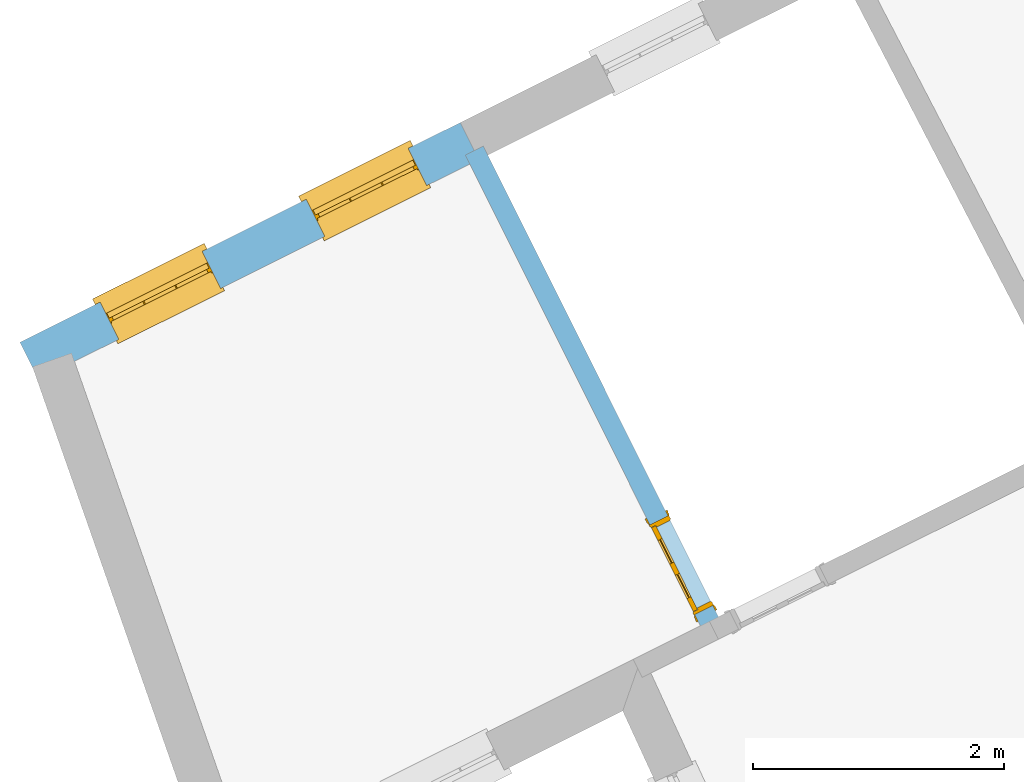
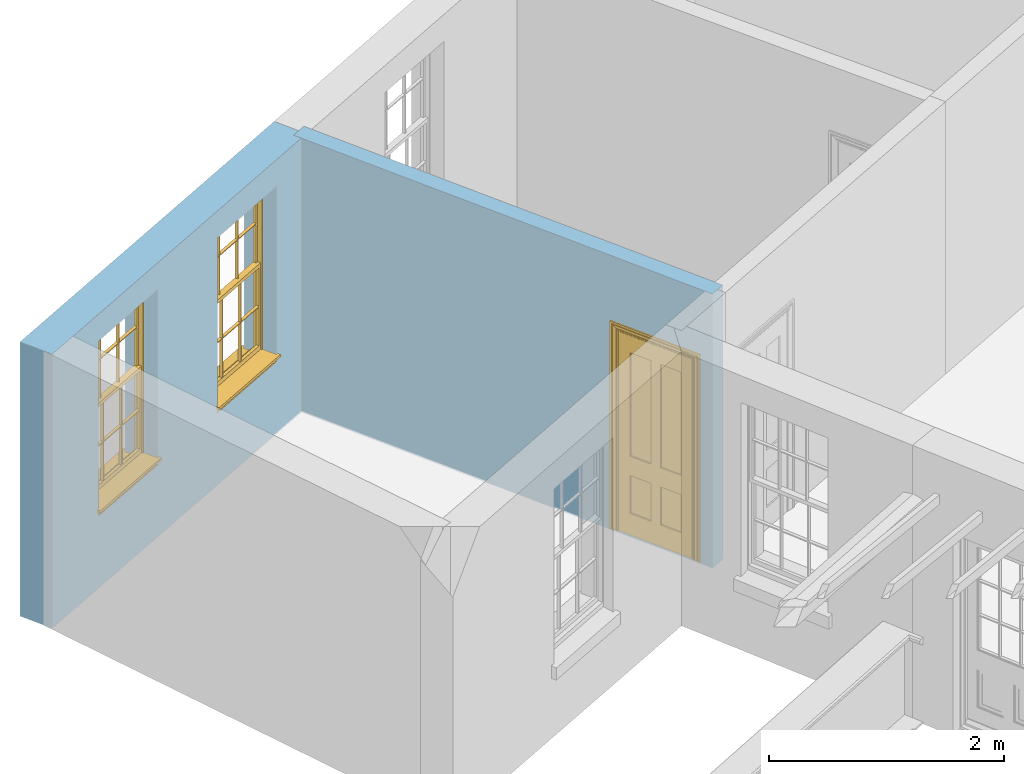
# One storey, part 5 of 9: 2 windows, 1 door, 3 openings, plus 2 elements that do not belong to this part.
"""IFC2X3 building model written with IfcOpenShell, lengths in metres."""

import ifcopenshell
import ifcopenshell.guid

model = None  # the IFC model being written
_history = None  # IfcOwnerHistory: only IFC2X3 demands one
_inside = {}  # id of a spatial element -> (the spatial element, [elements in it])
_under = {}  # id of a project, library or spatial element -> (it, [spatial elements below it])
_declared = {}  # id of a project -> (the project, [libraries it declares])
_typed = {}  # id of a type object -> (the type object, [elements of that type])
_made_of = {}  # id of a material, layer set ... -> (it, [elements and type objects made of it])


def new_model(schema):
    """Start an empty IFC model of exactly this schema.

    Asked for "IFC4X3", IfcOpenShell would pick the latest addendum, in which some entities
    have other attributes; the version numbers below select the first issue.
    IFC2X3 requires an IfcOwnerHistory on every rooted entity: one is made here for all.
    """
    global model, _history
    if schema == "IFC4X3":
        model = ifcopenshell.file(schema_version=(4, 3, 0, 0))
    else:
        model = ifcopenshell.file(schema=schema)
    _inside.clear()
    _under.clear()
    _declared.clear()
    _typed.clear()
    _made_of.clear()
    _history = None
    if model.schema == "IFC2X3":
        org = make("IfcOrganization", Name="unknown")
        user = make(
            "IfcPersonAndOrganization",
            ThePerson=make("IfcPerson", FamilyName="unknown"),
            TheOrganization=org,
        )
        app = make(
            "IfcApplication",
            ApplicationDeveloper=org,
            Version="unknown",
            ApplicationFullName="unknown",
            ApplicationIdentifier="unknown",
        )
        _history = make(
            "IfcOwnerHistory",
            OwningUser=user,
            OwningApplication=app,
            ChangeAction="ADDED",
            CreationDate=0,
        )
    return model


def make(cls, **values):
    """One entity of the class cls with the attributes given. An attribute that is None is left unset."""
    return model.create_entity(
        cls, **{name: value for name, value in values.items() if value is not None}
    )


def rooted(cls, **values):
    """An entity with a GlobalId (a new one), such as an element, a storey or a relation."""
    return make(cls, GlobalId=ifcopenshell.guid.new(), OwnerHistory=_history, **values)


def si_unit(unit_type, name, prefix=None):
    """IfcSIUnit, for example si_unit("LENGTHUNIT", "METRE", prefix="MILLI")."""
    return make("IfcSIUnit", UnitType=unit_type, Prefix=prefix, Name=name)


def assignment(units):
    """IfcUnitAssignment: the units of a project."""
    return None if units is None else make("IfcUnitAssignment", Units=units)


def point(xyz):
    """IfcCartesianPoint."""
    return None if xyz is None else make("IfcCartesianPoint", Coordinates=xyz)


def direction(xyz):
    """IfcDirection."""
    return None if xyz is None else make("IfcDirection", DirectionRatios=xyz)


def frame(location, z_axis=None, x_axis=None):
    """IfcAxis2Placement3D, a coordinate frame: its origin and axes. An axis left out is left unset."""
    return make(
        "IfcAxis2Placement3D",
        Location=point(location),
        Axis=direction(z_axis),
        RefDirection=direction(x_axis),
    )


def origin():
    """The frame at (0, 0, 0) with its axes left unset."""
    return frame((0.0, 0.0, 0.0))


def place(relative_to, where):
    """IfcLocalPlacement: puts the frame where relative to a parent placement (None: the world)."""
    return make(
        "IfcLocalPlacement", PlacementRelTo=relative_to, RelativePlacement=where
    )


def context(
    kind, dimensions, precision=None, world=None, true_north=None, identifier=None
):
    """IfcGeometricRepresentationContext, for example the 3D "Model" context."""
    return make(
        "IfcGeometricRepresentationContext",
        ContextIdentifier=identifier,
        ContextType=kind,
        CoordinateSpaceDimension=dimensions,
        Precision=precision,
        WorldCoordinateSystem=world,
        TrueNorth=true_north,
    )


def subcontext(parent, identifier, kind, view, scale=None):
    """IfcGeometricRepresentationSubContext, for example "Body" below "Model"."""
    return make(
        "IfcGeometricRepresentationSubContext",
        ContextIdentifier=identifier,
        ContextType=kind,
        ParentContext=parent,
        TargetScale=scale,
        TargetView=view,
    )


def project(units=None, contexts=None):
    """IfcProject with its units and contexts."""
    return rooted(
        "IfcProject",
        Name="project",
        RepresentationContexts=contexts,
        UnitsInContext=assignment(units),
    )


def spatial(cls, under=None, at=None, **own):
    """A site, building, storey or space (cls), placed at a placement, below another one or the project."""
    s = rooted(cls, ObjectPlacement=at, **own)
    if under is not None:
        _under.setdefault(under.id(), (under, []))[1].append(s)
    return s


def polyline(points):
    """IfcPolyline through the points."""
    return make("IfcPolyline", Points=[point(p) for p in points])


def outline(outer, holes=None, kind="AREA"):
    """IfcArbitraryClosedProfileDef: a profile drawn as a closed curve; with holes, ...WithVoids."""
    if holes is None:
        return make("IfcArbitraryClosedProfileDef", ProfileType=kind, OuterCurve=outer)
    return make(
        "IfcArbitraryProfileDefWithVoids",
        ProfileType=kind,
        OuterCurve=outer,
        InnerCurves=holes,
    )


def extrude(swept, where, along, depth):
    """IfcExtrudedAreaSolid: the profile swept, set in the frame where, extruded along a direction by depth."""
    return make(
        "IfcExtrudedAreaSolid",
        SweptArea=swept,
        Position=where,
        ExtrudedDirection=direction(along),
        Depth=depth,
    )


def faces_of(points, faces, orient=None, outer=None):
    """IfcFace entities. A face is a list of loops; a loop is a list of indices into points, from 0.

    orient and outer hold one flag for each loop. By default every Orientation is true, the
    first loop of a face is its IfcFaceOuterBound and the others are IfcFaceBound.
    """
    made = []
    for i, loops in enumerate(faces):
        bounds = []
        for j, loop in enumerate(loops):
            is_outer = j == 0 if outer is None else outer[i][j]
            bounds.append(
                make(
                    "IfcFaceOuterBound" if is_outer else "IfcFaceBound",
                    Bound=make("IfcPolyLoop", Polygon=[points[k] for k in loop]),
                    Orientation=True if orient is None else orient[i][j],
                )
            )
        made.append(make("IfcFace", Bounds=bounds))
    return made


def faceted_brep(points, faces, orient=None, outer=None, voids=None):
    """IfcFacetedBrep: a solid bounded by flat faces; with voids (closed shells), ...WithVoids."""
    shared = [point(p) for p in points]
    hull = make("IfcClosedShell", CfsFaces=faces_of(shared, faces, orient, outer))
    if voids is None:
        return make("IfcFacetedBrep", Outer=hull)
    return make(
        "IfcFacetedBrepWithVoids",
        Outer=hull,
        Voids=[
            make(cls, CfsFaces=faces_of(shared, fs, o, b)) for cls, fs, o, b in voids
        ],
    )


def shape(context_of_items, identifier, shape_type, items):
    """IfcShapeRepresentation: the items that make up one representation, for example the "Body"."""
    return make(
        "IfcShapeRepresentation",
        ContextOfItems=context_of_items,
        RepresentationIdentifier=identifier,
        RepresentationType=shape_type,
        Items=items,
    )


def material(Name=None, Category=None):
    """IfcMaterial."""
    return make("IfcMaterial", Name=Name, Category=Category)


def layer(
    of_material, thickness, ventilated=None, Name=None, Category=None, Priority=None
):
    """IfcMaterialLayer: one layer of a wall or slab, of a material (None: an air gap)."""
    return make(
        "IfcMaterialLayer",
        Material=of_material,
        LayerThickness=thickness,
        IsVentilated=ventilated,
        Name=Name,
        Category=Category,
        Priority=Priority,
    )


def layer_set(layers, Name=None):
    """IfcMaterialLayerSet."""
    return make("IfcMaterialLayerSet", MaterialLayers=layers, LayerSetName=Name)


def layer_usage(for_layer_set, set_direction, sense, offset, extent=None):
    """IfcMaterialLayerSetUsage: how a layer set lies in its element."""
    return make(
        "IfcMaterialLayerSetUsage",
        ForLayerSet=for_layer_set,
        LayerSetDirection=set_direction,
        DirectionSense=sense,
        OffsetFromReferenceLine=offset,
        ReferenceExtent=extent,
    )


def made_of(thing, what):
    """Note that an element or type object is made of a material, layer set ...; save() writes the relation."""
    if what is not None:
        _made_of.setdefault(what.id(), (what, []))[1].append(thing)
    return thing


def element(
    cls,
    number,
    at=None,
    inside=None,
    cuts=None,
    type_object=None,
    material=None,
    context=None,
    identifier="Body",
    shape_type=None,
    held_by="IfcProductDefinitionShape",
    body=None,
    shapes=None,
    **own,
):
    """One element of the class cls, such as IfcWall. Its Tag is "e" and its number.

    at: its placement. inside: the storey or other place that contains it. cuts: it is an
    opening in that element (IfcRelVoidsElement). A single representation is given by context,
    identifier, shape_type and body (its items); several are given by shapes. held_by: the class
    of the entity that holds the representations. save() writes the other relations.
    """
    e = rooted(cls, Tag="e%d" % number, ObjectPlacement=at, **own)
    if body is not None:
        shapes = [shape(context, identifier, shape_type, body)]
    if shapes is not None:
        e.Representation = make(held_by, Representations=shapes)
    if inside is not None:
        _inside.setdefault(inside.id(), (inside, []))[1].append(e)
    if cuts is not None:
        rooted(
            "IfcRelVoidsElement", RelatingBuildingElement=cuts, RelatedOpeningElement=e
        )
    if type_object is not None:
        _typed.setdefault(type_object.id(), (type_object, []))[1].append(e)
    return made_of(e, material)


def fill(opening, filler):
    """IfcRelFillsElement: the door or window that sits in an opening."""
    return rooted(
        "IfcRelFillsElement",
        RelatingOpeningElement=opening,
        RelatedBuildingElement=filler,
    )


def aggregate(whole, parts):
    """IfcRelAggregates: a whole, such as a stair, and the parts it consists of."""
    return rooted("IfcRelAggregates", RelatingObject=whole, RelatedObjects=parts)


def save(model, path):
    """Write the relations noted so far, then the file.

    IfcRelAggregates (storeys below a building ...), IfcRelContainedInSpatialStructure (elements
    in a storey), IfcRelDefinesByType, IfcRelAssociatesMaterial and IfcRelDeclares: one each for
    every whole, place, type object, material and project.
    """
    for whole, parts in _under.values():
        aggregate(whole, parts)
    for where, things in _inside.values():
        rooted(
            "IfcRelContainedInSpatialStructure",
            RelatedElements=things,
            RelatingStructure=where,
        )
    for kind, things in _typed.values():
        rooted("IfcRelDefinesByType", RelatedObjects=things, RelatingType=kind)
    for what, things in _made_of.values():
        rooted("IfcRelAssociatesMaterial", RelatedObjects=things, RelatingMaterial=what)
    for by, libraries in _declared.values():
        rooted("IfcRelDeclares", RelatingContext=by, RelatedDefinitions=libraries)
    model.write(path)


model = new_model("IFC2X3")

# Units and contexts
model_context = context("Model", 3, world=origin())
body_context = subcontext(model_context, "Body", "Model", "MODEL_VIEW")
ifc_project = project(units=[si_unit("PLANEANGLEUNIT", "RADIAN"), si_unit("MASSUNIT", "GRAM", prefix="KILO"), si_unit("FORCEUNIT", "NEWTON", prefix="KILO"), si_unit("LENGTHUNIT", "METRE")], contexts=[model_context])

# Site, building, storey
site_placement = place(None, origin())
site = spatial("IfcSite", under=ifc_project, at=site_placement, CompositionType="ELEMENT")
building_placement = place(None, origin())
building = spatial("IfcBuilding", under=site, at=building_placement, Name="Building plot-8", CompositionType="ELEMENT")
storey_placement = place(None, frame((0.0, 0.0, 3.45)))
storey = spatial("IfcBuildingStorey", under=building, at=storey_placement, Name="Floor 1", CompositionType="ELEMENT", Elevation=3.45)

# Wall, openings, windows
ifc_material_1 = material(Name="Masonry")
ifc_layer_1 = layer(ifc_material_1, 0.33, ventilated=False)
ifc_layer_set_1 = layer_set([ifc_layer_1], Name="My Wall")
ifc_layer_usage_1 = layer_usage(ifc_layer_set_1, "AXIS2", "NEGATIVE", 0.08)
wall_1_placement = place(storey_placement, origin())
wall_1 = element("IfcWallStandardCase", 1, at=wall_1_placement, inside=storey, material=ifc_layer_usage_1, Name="exterior", context=body_context, shape_type="SweptSolid", body=[
    extrude(outline(polyline([(22.5334147953, 17.1075198586967), (22.3860129541837, 17.4027700868685), (18.8749875286192, 15.6499124679644), (19.0223893697354, 15.3546622397925), (22.5334147953, 17.1075198586967)])), origin(), (0.0, 0.0, 1.0), 2.85),
])
opening_1_placement = place(storey_placement, frame((0.0, 0.0, 0.75)))
opening_1 = element("IfcOpeningElement", 2, at=opening_1_placement, cuts=wall_1, Name="Opening", ObjectType="Opening", context=body_context, shape_type="SweptSolid", body=[
    extrude(outline(polyline([(21.9712626374257, 17.1957085693475), (21.1570877658003, 16.7892368256633), (21.3044896069165, 16.4939865974914), (22.118664478542, 16.9004583411757), (21.9712626374257, 17.1957085693475)])), origin(), (0.0, 0.0, 1.0), 1.82),
])
opening_2_placement = place(storey_placement, frame((0.0, 0.0, 0.75)))
opening_2 = element("IfcOpeningElement", 3, at=opening_2_placement, cuts=wall_1, Name="Opening", ObjectType="Opening", context=body_context, shape_type="SweptSolid", body=[
    extrude(outline(polyline([(20.3275871322843, 16.3751137906213), (19.5134122606589, 15.9686420469371), (19.6608141017751, 15.6733918187652), (20.4749889734006, 16.0798635624495), (20.3275871322843, 16.3751137906213)])), origin(), (0.0, 0.0, 1.0), 1.82),
])
window_1_placement = place(storey_placement, frame((22.0829306988774, 16.9720341540658, 0.75), z_axis=(0.0, 0.0, 1.0), x_axis=(-0.814174871625433, -0.406471743684243, 0.0)))
window_1 = element("IfcWindow", 4, at=window_1_placement, inside=storey, Name="bedroom outside window", OverallHeight=1.82, OverallWidth=0.91, context=body_context, shape_type="Brep", held_by="IfcProductRepresentation", body=[
    faceted_brep([(0.033125, -0.105, 0.975209), (0.01, -0.105, 0.975209), (0.033125, -0.105, 1.376042), (0.876875, -0.105, 0.975209), (0.876875, -0.105, 1.376042), (0.9, -0.105, 0.975209), (0.876875, -0.105, 1.386042), (0.876875, -0.105, 1.786875), (0.9, -0.105, 1.81), (0.033125, -0.105, 1.786875), (0.033125, -0.105, 1.386042), (0.01, -0.105, 1.81), (0.876875, -0.135, 1.376042), (0.876875, -0.135, 0.975209), (0.9, -0.135, 0.937083), (0.033125, -0.135, 1.786875), (0.01, -0.135, 1.81), (0.033125, -0.135, 1.386042), (0.01, -0.135, 0.937083), (0.033125, -0.135, 0.975209), (0.033125, -0.135, 1.376042), (0.876875, -0.135, 1.786875), (0.876875, -0.135, 1.386042), (0.9, -0.135, 1.81), (0.033125, -0.105, 0.937083), (0.01, -0.105, 0.937083), (0.033125, -0.105, 0.53625), (0.876875, -0.105, 0.937083), (0.876875, -0.105, 0.53625), (0.9, -0.105, 0.937083), (0.876875, -0.105, 0.52625), (0.876875, -0.105, 0.125417), (0.9, -0.105, 0.077167), (0.033125, -0.105, 0.125417), (0.033125, -0.105, 0.52625), (0.01, -0.105, 0.077167), (-0.0425, -0.25, 0.01), (-0.0425, -0.3, 0.001667), (0.0, -0.25, 0.01), (0.9525, -0.25, 0.01), (0.91, -0.25, 0.01), (0.9525, -0.3, 0.001667), (-0.02, 0.08, 0.077167), (0.0, 0.08, 0.077167), (-0.02, 0.11, 0.077167), (0.0, -0.06, 0.077167), (0.01, -0.06, 0.077167), (0.91, -0.06, 0.077167), (0.91, 0.08, 0.077167), (0.9, -0.06, 0.077167), (0.93, 0.08, 0.077167), (0.93, 0.11, 0.077167), (0.01, -0.075, 0.975209), (0.9, -0.075, 0.975209), (0.876875, -0.075, 0.125417), (0.876875, -0.075, 0.52625), (0.9, -0.075, 0.077167), (0.876875, -0.075, 0.53625), (0.876875, -0.075, 0.937083), (0.033125, -0.075, 0.125417), (0.01, -0.075, 0.077167), (0.033125, -0.075, 0.52625), (0.033125, -0.075, 0.937083), (0.033125, -0.075, 0.53625), (-0.02, 0.08, 0.052167), (-0.02, 0.11, 0.052167), (0.93, 0.11, 0.052167), (0.93, 0.08, 0.052167), (0.91, 0.08, 0.052167), (0.0, 0.08, 0.052167), (0.91, -0.15, 0.026667), (0.0, -0.15, 0.026667), (-0.0425, -0.3, -0.123333), (0.9525, -0.3, -0.123333), (-0.0425, -0.25, -0.123333), (0.9525, -0.25, -0.123333), (0.01, -0.06, 1.81), (0.9, -0.06, 1.81), (0.0, -0.06, 1.82), (0.91, -0.06, 1.82), (0.01, -0.15, 0.077167), (0.9, -0.15, 0.077167), (0.592292, -0.105, 0.125417), (0.592292, -0.075, 0.125417), (0.317708, -0.075, 0.125417), (0.317708, -0.105, 0.125417), (0.592292, -0.105, 0.53625), (0.317708, -0.105, 0.53625), (0.317708, -0.105, 0.52625), (0.592292, -0.105, 0.52625), (0.592292, -0.075, 0.53625), (0.317708, -0.075, 0.53625), (0.592292, -0.135, 1.386042), (0.592292, -0.105, 1.386042), (0.317708, -0.105, 1.386042), (0.317708, -0.135, 1.386042), (0.317708, -0.135, 1.376042), (0.592292, -0.135, 1.376042), (0.317708, -0.105, 1.376042), (0.592292, -0.105, 1.376042), (0.602292, -0.135, 1.376042), (0.592292, -0.135, 0.975209), (0.602292, -0.135, 0.975209), (0.602292, -0.105, 0.975209), (0.592292, -0.105, 0.975209), (0.602292, -0.105, 1.376042), (0.602292, -0.075, 0.53625), (0.602292, -0.105, 0.53625), (0.317708, -0.075, 0.52625), (0.307708, -0.075, 0.125417), (0.307708, -0.075, 0.52625), (0.602292, -0.075, 0.52625), (0.602292, -0.075, 0.125417), (0.592292, -0.075, 0.52625), (0.307708, -0.075, 0.53625), (0.317708, -0.075, 0.937083), (0.307708, -0.075, 0.937083), (0.602292, -0.075, 0.937083), (0.592292, -0.075, 0.937083), (0.307708, -0.105, 0.52625), (0.307708, -0.105, 0.125417), (0.307708, -0.105, 0.53625), (0.307708, -0.105, 0.937083), (0.592292, -0.105, 0.937083), (0.317708, -0.105, 0.937083), (0.602292, -0.105, 0.937083), (0.602292, -0.105, 0.52625), (0.602292, -0.105, 0.125417), (0.307708, -0.135, 1.386042), (0.307708, -0.135, 1.376042), (0.307708, -0.135, 0.975209), (0.317708, -0.135, 0.975209), (0.317708, -0.135, 1.786875), (0.307708, -0.135, 1.786875), (0.602292, -0.135, 1.786875), (0.592292, -0.135, 1.786875), (0.602292, -0.135, 1.386042), (0.602292, -0.105, 1.386042), (0.307708, -0.105, 1.386042), (0.307708, -0.105, 1.786875), (0.317708, -0.105, 1.786875), (0.592292, -0.105, 1.786875), (0.602292, -0.105, 1.786875), (0.307708, -0.105, 1.376042), (0.317708, -0.105, 0.975209), (0.307708, -0.105, 0.975209), (0.91, -0.15, 1.82), (0.9, -0.15, 1.81), (0.01, -0.15, 1.81), (0.0, -0.15, 1.82), (0.91, -0.25, 0.0), (0.0, -0.25, 0.0), (0.91, 0.08, 0.0), (0.0, 0.08, 0.0)], [[[0, 1, 2]], [[3, 4, 5]], [[6, 7, 8]], [[9, 10, 11]], [[12, 13, 14]], [[15, 16, 17]], [[18, 19, 20]], [[21, 22, 23]], [[24, 25, 26]], [[27, 28, 29]], [[30, 31, 32]], [[33, 34, 35]], [[14, 27, 29]], [[25, 24, 18]], [[36, 37, 38]], [[39, 40, 41]], [[42, 43, 44]], [[45, 46, 43]], [[47, 48, 49]], [[50, 51, 48]], [[1, 0, 52]], [[5, 53, 3]], [[54, 55, 56]], [[57, 58, 53]], [[59, 60, 61]], [[62, 63, 52]], [[48, 43, 46, 49]], [[51, 44, 43, 48]], [[64, 42, 44, 65]], [[65, 44, 51, 66]], [[66, 51, 50, 67]], [[65, 66, 68, 69]], [[60, 56, 49, 46]], [[70, 71, 38, 40]], [[37, 41, 40, 38]], [[37, 72, 73, 41]], [[74, 75, 73, 72]], [[8, 11, 76, 77]], [[76, 78, 79, 77]], [[32, 35, 80, 81]], [[81, 80, 71, 70]], [[82, 83, 84, 85]], [[86, 87, 88, 89]], [[86, 90, 91, 87]], [[92, 93, 94, 95]], [[92, 95, 96, 97]], [[96, 98, 99, 97]], [[100, 97, 101, 102]], [[103, 104, 99, 105]], [[97, 99, 104, 101]], [[102, 103, 105, 100]], [[28, 57, 106, 107]], [[108, 84, 109, 110]], [[111, 112, 83, 113]], [[114, 110, 61, 63]], [[90, 113, 108, 91]], [[115, 91, 114, 116]], [[117, 106, 90, 118]], [[111, 106, 57, 55]], [[119, 110, 109, 120]], [[34, 61, 110, 119]], [[89, 113, 83, 82]], [[88, 108, 113, 89]], [[85, 84, 108, 88]], [[121, 114, 63, 26]], [[122, 116, 114, 121]], [[123, 118, 90, 86]], [[87, 91, 115, 124]], [[107, 106, 117, 125]], [[126, 111, 55, 30]], [[127, 112, 111, 126]], [[126, 30, 28, 107]], [[88, 119, 120, 85]], [[126, 89, 82, 127]], [[125, 123, 86, 107]], [[121, 26, 34, 119]], [[124, 122, 121, 87]], [[128, 17, 20, 129]], [[96, 129, 130, 131]], [[132, 133, 128, 95]], [[134, 135, 92, 136]], [[100, 12, 22, 136]], [[137, 6, 4, 105]], [[94, 138, 139, 140]], [[137, 93, 141, 142]], [[99, 98, 94, 93]], [[143, 2, 10, 138]], [[144, 145, 143, 98]], [[129, 143, 145, 130]], [[20, 2, 143, 129]], [[131, 144, 98, 96]], [[128, 138, 10, 17]], [[133, 139, 138, 128]], [[135, 141, 93, 92]], [[95, 94, 140, 132]], [[22, 6, 137, 136]], [[136, 137, 142, 134]], [[100, 105, 4, 12]], [[107, 86, 89, 126]], [[106, 111, 113, 90]], [[91, 108, 110, 114]], [[87, 121, 119, 88]], [[97, 100, 136, 92]], [[129, 96, 95, 128]], [[98, 143, 138, 94]], [[105, 99, 93, 137]], [[131, 101, 104, 144]], [[124, 115, 118, 123]], [[132, 140, 141, 135]], [[120, 109, 59, 33]], [[15, 9, 139, 133]], [[134, 142, 7, 21]], [[31, 54, 112, 127]], [[36, 74, 72, 37]], [[39, 41, 73, 75]], [[18, 14, 101, 131]], [[23, 16, 132, 135]], [[83, 56, 60, 84]], [[52, 53, 118, 115]], [[53, 52, 144, 104]], [[11, 8, 141, 140]], [[14, 18, 124, 123]], [[2, 1, 11, 10]], [[8, 5, 4, 6]], [[57, 53, 56, 55]], [[60, 52, 63, 61]], [[26, 25, 35, 34]], [[32, 29, 28, 30]], [[14, 23, 22, 12]], [[18, 20, 17, 16]], [[19, 0, 2, 20]], [[17, 10, 9, 15]], [[12, 4, 3, 13]], [[21, 7, 6, 22]], [[27, 58, 57, 28]], [[30, 55, 54, 31]], [[33, 59, 61, 34]], [[26, 63, 62, 24]], [[5, 8, 77, 53]], [[76, 11, 1, 52]], [[46, 45, 78, 76]], [[49, 77, 79, 47]], [[70, 146, 147, 81]], [[71, 80, 148, 149]], [[19, 130, 145, 0]], [[102, 13, 3, 103]], [[116, 122, 24, 62]], [[29, 32, 81, 14]], [[80, 35, 25, 18]], [[60, 46, 76, 52]], [[77, 49, 56, 53]], [[23, 14, 81, 147]], [[16, 148, 80, 18]], [[35, 85, 120]], [[120, 33, 35]], [[127, 82, 32]], [[32, 31, 127]], [[32, 82, 85, 35]], [[102, 101, 14]], [[14, 13, 102]], [[18, 131, 130]], [[130, 19, 18]], [[134, 21, 23]], [[23, 135, 134]], [[16, 15, 133]], [[133, 132, 16]], [[11, 140, 139]], [[139, 9, 11]], [[142, 141, 8]], [[8, 7, 142]], [[23, 147, 148, 16]], [[146, 149, 148, 147]], [[52, 115, 116]], [[116, 62, 52]], [[118, 53, 117]], [[58, 117, 53]], [[27, 125, 117, 58]], [[56, 83, 112]], [[112, 54, 56]], [[109, 84, 60]], [[60, 59, 109]], [[125, 27, 14]], [[14, 123, 125]], [[122, 124, 18]], [[18, 24, 122]], [[145, 144, 52]], [[52, 0, 145]], [[103, 3, 53]], [[53, 104, 103]], [[79, 78, 149, 146]], [[78, 45, 71, 149]], [[146, 70, 47, 79]], [[150, 75, 74, 151]], [[68, 66, 67]], [[48, 68, 67, 50]], [[69, 64, 65]], [[42, 64, 69, 43]], [[69, 68, 152, 153]], [[70, 68, 48, 47]], [[150, 152, 68, 70]], [[43, 69, 71, 45]], [[69, 153, 151, 71]], [[152, 150, 151, 153]], [[38, 151, 74, 36]], [[71, 151, 38]], [[39, 75, 150, 40]], [[40, 150, 70]]]),
])
fill(opening_1, window_1)
window_2_placement = place(storey_placement, frame((20.439255193736, 16.1514393753396, 0.75), z_axis=(0.0, 0.0, 1.0), x_axis=(-0.814174871625433, -0.406471743684243, 0.0)))
window_2 = element("IfcWindow", 5, at=window_2_placement, inside=storey, Name="bedroom outside window", OverallHeight=1.82, OverallWidth=0.91, context=body_context, shape_type="Brep", held_by="IfcProductRepresentation", body=[
    faceted_brep([(0.033125, -0.105, 0.975209), (0.01, -0.105, 0.975209), (0.033125, -0.105, 1.376042), (0.876875, -0.105, 0.975209), (0.876875, -0.105, 1.376042), (0.9, -0.105, 0.975209), (0.876875, -0.105, 1.386042), (0.876875, -0.105, 1.786875), (0.9, -0.105, 1.81), (0.033125, -0.105, 1.786875), (0.033125, -0.105, 1.386042), (0.01, -0.105, 1.81), (0.876875, -0.135, 1.376042), (0.876875, -0.135, 0.975209), (0.9, -0.135, 0.937083), (0.033125, -0.135, 1.786875), (0.01, -0.135, 1.81), (0.033125, -0.135, 1.386042), (0.01, -0.135, 0.937083), (0.033125, -0.135, 0.975209), (0.033125, -0.135, 1.376042), (0.876875, -0.135, 1.786875), (0.876875, -0.135, 1.386042), (0.9, -0.135, 1.81), (0.033125, -0.105, 0.937083), (0.01, -0.105, 0.937083), (0.033125, -0.105, 0.53625), (0.876875, -0.105, 0.937083), (0.876875, -0.105, 0.53625), (0.9, -0.105, 0.937083), (0.876875, -0.105, 0.52625), (0.876875, -0.105, 0.125417), (0.9, -0.105, 0.077167), (0.033125, -0.105, 0.125417), (0.033125, -0.105, 0.52625), (0.01, -0.105, 0.077167), (-0.0425, -0.25, 0.01), (-0.0425, -0.3, 0.001667), (0.0, -0.25, 0.01), (0.9525, -0.25, 0.01), (0.91, -0.25, 0.01), (0.9525, -0.3, 0.001667), (-0.02, 0.08, 0.077167), (0.0, 0.08, 0.077167), (-0.02, 0.11, 0.077167), (0.0, -0.06, 0.077167), (0.01, -0.06, 0.077167), (0.91, -0.06, 0.077167), (0.91, 0.08, 0.077167), (0.9, -0.06, 0.077167), (0.93, 0.08, 0.077167), (0.93, 0.11, 0.077167), (0.01, -0.075, 0.975209), (0.9, -0.075, 0.975209), (0.876875, -0.075, 0.125417), (0.876875, -0.075, 0.52625), (0.9, -0.075, 0.077167), (0.876875, -0.075, 0.53625), (0.876875, -0.075, 0.937083), (0.033125, -0.075, 0.125417), (0.01, -0.075, 0.077167), (0.033125, -0.075, 0.52625), (0.033125, -0.075, 0.937083), (0.033125, -0.075, 0.53625), (-0.02, 0.08, 0.052167), (-0.02, 0.11, 0.052167), (0.93, 0.11, 0.052167), (0.93, 0.08, 0.052167), (0.91, 0.08, 0.052167), (0.0, 0.08, 0.052167), (0.91, -0.15, 0.026667), (0.0, -0.15, 0.026667), (-0.0425, -0.3, -0.123333), (0.9525, -0.3, -0.123333), (-0.0425, -0.25, -0.123333), (0.9525, -0.25, -0.123333), (0.01, -0.06, 1.81), (0.9, -0.06, 1.81), (0.0, -0.06, 1.82), (0.91, -0.06, 1.82), (0.01, -0.15, 0.077167), (0.9, -0.15, 0.077167), (0.592292, -0.105, 0.125417), (0.592292, -0.075, 0.125417), (0.317708, -0.075, 0.125417), (0.317708, -0.105, 0.125417), (0.592292, -0.105, 0.53625), (0.317708, -0.105, 0.53625), (0.317708, -0.105, 0.52625), (0.592292, -0.105, 0.52625), (0.592292, -0.075, 0.53625), (0.317708, -0.075, 0.53625), (0.592292, -0.135, 1.386042), (0.592292, -0.105, 1.386042), (0.317708, -0.105, 1.386042), (0.317708, -0.135, 1.386042), (0.317708, -0.135, 1.376042), (0.592292, -0.135, 1.376042), (0.317708, -0.105, 1.376042), (0.592292, -0.105, 1.376042), (0.602292, -0.135, 1.376042), (0.592292, -0.135, 0.975209), (0.602292, -0.135, 0.975209), (0.602292, -0.105, 0.975209), (0.592292, -0.105, 0.975209), (0.602292, -0.105, 1.376042), (0.602292, -0.075, 0.53625), (0.602292, -0.105, 0.53625), (0.317708, -0.075, 0.52625), (0.307708, -0.075, 0.125417), (0.307708, -0.075, 0.52625), (0.602292, -0.075, 0.52625), (0.602292, -0.075, 0.125417), (0.592292, -0.075, 0.52625), (0.307708, -0.075, 0.53625), (0.317708, -0.075, 0.937083), (0.307708, -0.075, 0.937083), (0.602292, -0.075, 0.937083), (0.592292, -0.075, 0.937083), (0.307708, -0.105, 0.52625), (0.307708, -0.105, 0.125417), (0.307708, -0.105, 0.53625), (0.307708, -0.105, 0.937083), (0.592292, -0.105, 0.937083), (0.317708, -0.105, 0.937083), (0.602292, -0.105, 0.937083), (0.602292, -0.105, 0.52625), (0.602292, -0.105, 0.125417), (0.307708, -0.135, 1.386042), (0.307708, -0.135, 1.376042), (0.307708, -0.135, 0.975209), (0.317708, -0.135, 0.975209), (0.317708, -0.135, 1.786875), (0.307708, -0.135, 1.786875), (0.602292, -0.135, 1.786875), (0.592292, -0.135, 1.786875), (0.602292, -0.135, 1.386042), (0.602292, -0.105, 1.386042), (0.307708, -0.105, 1.386042), (0.307708, -0.105, 1.786875), (0.317708, -0.105, 1.786875), (0.592292, -0.105, 1.786875), (0.602292, -0.105, 1.786875), (0.307708, -0.105, 1.376042), (0.317708, -0.105, 0.975209), (0.307708, -0.105, 0.975209), (0.91, -0.15, 1.82), (0.9, -0.15, 1.81), (0.01, -0.15, 1.81), (0.0, -0.15, 1.82), (0.91, -0.25, 0.0), (0.0, -0.25, 0.0), (0.91, 0.08, 0.0), (0.0, 0.08, 0.0)], [[[0, 1, 2]], [[3, 4, 5]], [[6, 7, 8]], [[9, 10, 11]], [[12, 13, 14]], [[15, 16, 17]], [[18, 19, 20]], [[21, 22, 23]], [[24, 25, 26]], [[27, 28, 29]], [[30, 31, 32]], [[33, 34, 35]], [[14, 27, 29]], [[25, 24, 18]], [[36, 37, 38]], [[39, 40, 41]], [[42, 43, 44]], [[45, 46, 43]], [[47, 48, 49]], [[50, 51, 48]], [[1, 0, 52]], [[5, 53, 3]], [[54, 55, 56]], [[57, 58, 53]], [[59, 60, 61]], [[62, 63, 52]], [[48, 43, 46, 49]], [[51, 44, 43, 48]], [[64, 42, 44, 65]], [[65, 44, 51, 66]], [[66, 51, 50, 67]], [[65, 66, 68, 69]], [[60, 56, 49, 46]], [[70, 71, 38, 40]], [[37, 41, 40, 38]], [[37, 72, 73, 41]], [[74, 75, 73, 72]], [[8, 11, 76, 77]], [[76, 78, 79, 77]], [[32, 35, 80, 81]], [[81, 80, 71, 70]], [[82, 83, 84, 85]], [[86, 87, 88, 89]], [[86, 90, 91, 87]], [[92, 93, 94, 95]], [[92, 95, 96, 97]], [[96, 98, 99, 97]], [[100, 97, 101, 102]], [[103, 104, 99, 105]], [[97, 99, 104, 101]], [[102, 103, 105, 100]], [[28, 57, 106, 107]], [[108, 84, 109, 110]], [[111, 112, 83, 113]], [[114, 110, 61, 63]], [[90, 113, 108, 91]], [[115, 91, 114, 116]], [[117, 106, 90, 118]], [[111, 106, 57, 55]], [[119, 110, 109, 120]], [[34, 61, 110, 119]], [[89, 113, 83, 82]], [[88, 108, 113, 89]], [[85, 84, 108, 88]], [[121, 114, 63, 26]], [[122, 116, 114, 121]], [[123, 118, 90, 86]], [[87, 91, 115, 124]], [[107, 106, 117, 125]], [[126, 111, 55, 30]], [[127, 112, 111, 126]], [[126, 30, 28, 107]], [[88, 119, 120, 85]], [[126, 89, 82, 127]], [[125, 123, 86, 107]], [[121, 26, 34, 119]], [[124, 122, 121, 87]], [[128, 17, 20, 129]], [[96, 129, 130, 131]], [[132, 133, 128, 95]], [[134, 135, 92, 136]], [[100, 12, 22, 136]], [[137, 6, 4, 105]], [[94, 138, 139, 140]], [[137, 93, 141, 142]], [[99, 98, 94, 93]], [[143, 2, 10, 138]], [[144, 145, 143, 98]], [[129, 143, 145, 130]], [[20, 2, 143, 129]], [[131, 144, 98, 96]], [[128, 138, 10, 17]], [[133, 139, 138, 128]], [[135, 141, 93, 92]], [[95, 94, 140, 132]], [[22, 6, 137, 136]], [[136, 137, 142, 134]], [[100, 105, 4, 12]], [[107, 86, 89, 126]], [[106, 111, 113, 90]], [[91, 108, 110, 114]], [[87, 121, 119, 88]], [[97, 100, 136, 92]], [[129, 96, 95, 128]], [[98, 143, 138, 94]], [[105, 99, 93, 137]], [[131, 101, 104, 144]], [[124, 115, 118, 123]], [[132, 140, 141, 135]], [[120, 109, 59, 33]], [[15, 9, 139, 133]], [[134, 142, 7, 21]], [[31, 54, 112, 127]], [[36, 74, 72, 37]], [[39, 41, 73, 75]], [[18, 14, 101, 131]], [[23, 16, 132, 135]], [[83, 56, 60, 84]], [[52, 53, 118, 115]], [[53, 52, 144, 104]], [[11, 8, 141, 140]], [[14, 18, 124, 123]], [[2, 1, 11, 10]], [[8, 5, 4, 6]], [[57, 53, 56, 55]], [[60, 52, 63, 61]], [[26, 25, 35, 34]], [[32, 29, 28, 30]], [[14, 23, 22, 12]], [[18, 20, 17, 16]], [[19, 0, 2, 20]], [[17, 10, 9, 15]], [[12, 4, 3, 13]], [[21, 7, 6, 22]], [[27, 58, 57, 28]], [[30, 55, 54, 31]], [[33, 59, 61, 34]], [[26, 63, 62, 24]], [[5, 8, 77, 53]], [[76, 11, 1, 52]], [[46, 45, 78, 76]], [[49, 77, 79, 47]], [[70, 146, 147, 81]], [[71, 80, 148, 149]], [[19, 130, 145, 0]], [[102, 13, 3, 103]], [[116, 122, 24, 62]], [[29, 32, 81, 14]], [[80, 35, 25, 18]], [[60, 46, 76, 52]], [[77, 49, 56, 53]], [[23, 14, 81, 147]], [[16, 148, 80, 18]], [[35, 85, 120]], [[120, 33, 35]], [[127, 82, 32]], [[32, 31, 127]], [[32, 82, 85, 35]], [[102, 101, 14]], [[14, 13, 102]], [[18, 131, 130]], [[130, 19, 18]], [[134, 21, 23]], [[23, 135, 134]], [[16, 15, 133]], [[133, 132, 16]], [[11, 140, 139]], [[139, 9, 11]], [[142, 141, 8]], [[8, 7, 142]], [[23, 147, 148, 16]], [[146, 149, 148, 147]], [[52, 115, 116]], [[116, 62, 52]], [[118, 53, 117]], [[58, 117, 53]], [[27, 125, 117, 58]], [[56, 83, 112]], [[112, 54, 56]], [[109, 84, 60]], [[60, 59, 109]], [[125, 27, 14]], [[14, 123, 125]], [[122, 124, 18]], [[18, 24, 122]], [[145, 144, 52]], [[52, 0, 145]], [[103, 3, 53]], [[53, 104, 103]], [[79, 78, 149, 146]], [[78, 45, 71, 149]], [[146, 70, 47, 79]], [[150, 75, 74, 151]], [[68, 66, 67]], [[48, 68, 67, 50]], [[69, 64, 65]], [[42, 64, 69, 43]], [[69, 68, 152, 153]], [[70, 68, 48, 47]], [[150, 152, 68, 70]], [[43, 69, 71, 45]], [[69, 153, 151, 71]], [[152, 150, 151, 153]], [[38, 151, 74, 36]], [[71, 151, 38]], [[39, 75, 150, 40]], [[40, 150, 70]]]),
])
fill(opening_2, window_2)

# Wall, opening, door
ifc_material_2 = material(Name="Masonry")
ifc_layer_2 = layer(ifc_material_2, 0.16, ventilated=False)
ifc_layer_set_2 = layer_set([ifc_layer_2], Name="My Wall")
ifc_layer_usage_2 = layer_usage(ifc_layer_set_2, "AXIS2", "NEGATIVE", 0.08)
wall_2_placement = place(storey_placement, origin())
wall_2 = element("IfcWallStandardCase", 6, at=wall_2_placement, inside=storey, material=ifc_layer_usage_2, Name="interior", context=body_context, shape_type="SweptSolid", body=[
    extrude(outline(polyline([(24.3359654417437, 13.3178555951871), (24.4791170675239, 13.3893231545162), (22.5692568285255, 17.2148294512514), (22.4261052027453, 17.1433618919223), (24.3359654417437, 13.3178555951871)])), origin(), (0.0, 0.0, 1.0), 2.85),
])
opening_3_placement = place(storey_placement, frame((0.0, 0.0, 0.02)))
opening_3 = element("IfcOpeningElement", 7, at=opening_3_placement, cuts=wall_2, Name="Opening", ObjectType="Opening", context=body_context, shape_type="SweptSolid", body=[
    extrude(outline(polyline([(24.3987160632787, 13.5503687335191), (24.0413782666332, 14.2661268624206), (23.8982266408529, 14.1946593030915), (24.2555644374984, 13.47890117419), (24.3987160632787, 13.5503687335191)])), origin(), (0.0, 0.0, 1.0), 2.1),
])
door_placement = place(storey_placement, frame((24.3271402503886, 13.5146349538545, 0.02), z_axis=(0.0, 0.0, 1.0), x_axis=(-0.357337796645499, 0.715758128901474, 0.0)))
door = element("IfcDoor", 8, at=door_placement, inside=storey, Name="bedroom inside door", OverallHeight=2.1, OverallWidth=0.8, context=body_context, shape_type="Brep", held_by="IfcProductRepresentation", body=[
    faceted_brep([(0.773, 0.08, 1.895), (0.66, 0.08, 1.895), (0.66, 0.08, 2.073), (0.773, 0.08, 2.073), (0.773, 0.08, 0.82), (0.66, 0.08, 0.82), (0.45, 0.08, 1.895), (0.45, 0.08, 2.073), (0.773, 0.08, 0.62), (0.66, 0.08, 0.62), (0.66, 0.065, 0.82), (0.66, 0.065, 1.895), (0.45, 0.065, 1.895), (0.35, 0.08, 1.895), (0.35, 0.08, 2.073), (0.773, 0.08, 0.225), (0.66, 0.08, 0.225), (0.45, 0.08, 0.62), (0.45, 0.08, 0.82), (0.45, 0.065, 0.82), (0.35, 0.08, 0.82), (0.14, 0.08, 2.073), (0.14, 0.08, 1.895), (0.773, 0.08, 0.0), (0.66, 0.08, 0.0), (0.66, 0.065, 0.225), (0.66, 0.065, 0.62), (0.45, 0.065, 0.62), (0.35, 0.08, 0.62), (0.35, 0.065, 0.82), (0.35, 0.065, 1.895), (0.14, 0.065, 1.895), (0.027, 0.08, 2.073), (0.027, 0.08, 1.895), (0.773, 0.042, 0.0), (0.66, 0.042, 0.0), (0.45, 0.08, 0.0), (0.45, 0.08, 0.225), (0.45, 0.065, 0.225), (0.35, 0.08, 0.225), (0.14, 0.08, 0.82), (0.14, 0.08, 0.62), (0.14, 0.065, 0.82), (0.027, 0.08, 0.82), (0.773, 0.042, 0.225), (0.66, 0.042, 0.225), (0.45, 0.042, 0.0), (0.35, 0.08, 0.0), (0.35, 0.065, 0.225), (0.35, 0.065, 0.62), (0.14, 0.065, 0.62), (0.027, 0.08, 0.62), (0.773, 0.042, 0.62), (0.66, 0.042, 0.62), (0.45, 0.042, 0.225), (0.35, 0.042, 0.0), (0.14, 0.08, 0.225), (0.14, 0.08, 0.0), (0.14, 0.065, 0.225), (0.027, 0.08, 0.225), (0.773, 0.042, 0.82), (0.66, 0.042, 0.82), (0.66, 0.057, 0.62), (0.66, 0.057, 0.225), (0.45, 0.057, 0.225), (0.35, 0.042, 0.225), (0.14, 0.042, 0.0), (0.027, 0.08, 0.0), (0.773, 0.042, 1.895), (0.66, 0.042, 1.895), (0.45, 0.042, 0.62), (0.45, 0.042, 0.82), (0.45, 0.057, 0.62), (0.35, 0.042, 0.62), (0.14, 0.042, 0.225), (0.027, 0.042, 0.0), (0.773, 0.042, 2.073), (0.66, 0.042, 2.073), (0.66, 0.057, 1.895), (0.66, 0.057, 0.82), (0.45, 0.057, 0.82), (0.35, 0.042, 0.82), (0.35, 0.057, 0.62), (0.35, 0.057, 0.225), (0.14, 0.057, 0.225), (0.027, 0.042, 0.225), (0.45, 0.042, 1.895), (0.45, 0.042, 2.073), (0.45, 0.057, 1.895), (0.35, 0.042, 1.895), (0.14, 0.042, 0.82), (0.14, 0.042, 0.62), (0.14, 0.057, 0.62), (0.027, 0.042, 0.62), (0.35, 0.042, 2.073), (0.35, 0.057, 1.895), (0.35, 0.057, 0.82), (0.14, 0.057, 0.82), (0.027, 0.042, 0.82), (0.14, 0.042, 2.073), (0.14, 0.042, 1.895), (0.14, 0.057, 1.895), (0.027, 0.042, 1.895), (0.027, 0.042, 2.073), (0.02, 0.085, 0.0), (0.005, 0.09, 0.0), (0.005, 0.09, 2.095), (0.02, 0.085, 2.08), (0.02, 0.08, 0.0), (0.0, 0.085, 0.0), (0.0, 0.085, 2.1), (0.795, 0.09, 2.095), (0.78, 0.085, 2.08), (0.02, 0.08, 2.08), (0.0, 0.08, 0.0), (-0.032, 0.095, 0.0), (-0.032, 0.095, 2.132), (0.8, 0.085, 2.1), (0.795, 0.09, 0.0), (0.78, 0.085, 0.0), (0.78, 0.08, 2.08), (0.04, 0.04, 0.0), (0.025, 0.04, 0.0), (0.025, 0.04, 2.075), (0.04, 0.04, 2.06), (-0.04, 0.09, 0.0), (-0.04, 0.09, 2.14), (0.832, 0.095, 2.132), (0.8, 0.085, 0.0), (0.78, 0.08, 0.0), (0.8, 0.08, 0.0), (0.86, 0.08, 0.0), (0.86, 0.08, 2.16), (0.8, 0.08, 2.1), (-0.06, 0.08, 2.16), (0.0, 0.08, 2.1), (-0.06, 0.08, 0.0), (-0.04, 0.095, 0.0), (-0.04, 0.095, 2.14), (0.84, 0.09, 2.14), (0.832, 0.095, 0.0), (0.84, 0.09, 0.0), (0.86, 0.095, 0.0), (0.86, 0.095, 2.16), (-0.06, 0.095, 2.16), (-0.06, 0.095, 0.0), (0.84, 0.095, 0.0), (0.84, 0.095, 2.14), (-0.025, -0.095, 0.0), (-0.025, -0.09, 0.0), (-0.025, -0.09, 2.125), (-0.025, -0.095, 2.125), (-0.017, -0.095, 0.0), (-0.017, -0.095, 2.117), (0.825, -0.09, 2.125), (0.825, -0.095, 2.125), (0.825, -0.095, 0.0), (0.845, -0.095, 0.0), (-0.045, -0.095, 2.145), (-0.045, -0.095, 0.0), (0.845, -0.095, 2.145), (0.015, -0.085, 0.0), (0.015, -0.085, 2.085), (0.817, -0.095, 2.117), (0.825, -0.09, 0.0), (0.845, -0.08, 0.0), (0.845, -0.08, 2.145), (-0.045, -0.08, 2.145), (-0.045, -0.08, 0.0), (0.02, -0.09, 0.0), (0.02, -0.09, 2.08), (0.785, -0.085, 2.085), (0.817, -0.095, 0.0), (0.8, -0.08, 0.0), (0.8, -0.08, 2.1), (0.0, -0.08, 2.1), (0.0, -0.08, 0.0), (0.035, -0.085, 0.0), (0.035, -0.085, 2.065), (0.78, -0.09, 2.08), (0.785, -0.085, 0.0), (0.775, 0.04, 2.075), (0.76, 0.04, 2.06), (0.035, -0.08, 2.065), (0.035, -0.08, 0.0), (0.765, -0.085, 2.065), (0.78, -0.09, 0.0), (0.765, -0.08, 0.0), (0.765, -0.08, 2.065), (0.765, -0.085, 0.0), (0.04, -0.08, 2.06), (0.04, -0.08, 0.0), (0.76, -0.08, 2.06), (0.76, -0.08, 0.0), (0.76, 0.04, 0.0), (0.775, 0.04, 0.0), (0.025, 0.08, 0.0), (0.025, 0.08, 2.075), (0.775, 0.08, 0.0), (0.775, 0.08, 2.075)], [[[0, 1, 2, 3]], [[1, 0, 4, 5]], [[1, 6, 7, 2]], [[8, 9, 5, 4]], [[1, 5, 10, 11]], [[6, 1, 11, 12]], [[6, 13, 14, 7]], [[15, 16, 9, 8]], [[9, 17, 18, 5]], [[5, 18, 19, 10]], [[10, 19, 12, 11]], [[18, 6, 12, 19]], [[18, 20, 13, 6]], [[21, 14, 13, 22]], [[23, 24, 16, 15]], [[9, 16, 25, 26]], [[17, 9, 26, 27]], [[17, 28, 20, 18]], [[13, 20, 29, 30]], [[22, 13, 30, 31]], [[32, 21, 22, 33]], [[34, 35, 24, 23]], [[24, 36, 37, 16]], [[16, 37, 38, 25]], [[25, 38, 27, 26]], [[37, 17, 27, 38]], [[37, 39, 28, 17]], [[40, 20, 28, 41]], [[20, 40, 42, 29]], [[31, 30, 29, 42]], [[40, 22, 31, 42]], [[33, 22, 40, 43]], [[35, 34, 44, 45]], [[35, 46, 36, 24]], [[36, 47, 39, 37]], [[28, 39, 48, 49]], [[41, 28, 49, 50]], [[43, 40, 41, 51]], [[45, 44, 52, 53]], [[46, 35, 45, 54]], [[46, 55, 47, 36]], [[56, 39, 47, 57]], [[39, 56, 58, 48]], [[50, 49, 48, 58]], [[56, 41, 50, 58]], [[51, 41, 56, 59]], [[53, 52, 60, 61]], [[45, 53, 62, 63]], [[54, 45, 63, 64]], [[55, 46, 54, 65]], [[55, 66, 57, 47]], [[59, 56, 57, 67]], [[61, 60, 68, 69]], [[70, 53, 61, 71]], [[53, 70, 72, 62]], [[72, 64, 63, 62]], [[70, 54, 64, 72]], [[65, 54, 70, 73]], [[65, 74, 66, 55]], [[67, 57, 66, 75]], [[69, 68, 76, 77]], [[61, 69, 78, 79]], [[71, 61, 79, 80]], [[73, 70, 71, 81]], [[65, 73, 82, 83]], [[74, 65, 83, 84]], [[74, 85, 75, 66]], [[86, 69, 77, 87]], [[69, 86, 88, 78]], [[88, 80, 79, 78]], [[86, 71, 80, 88]], [[81, 71, 86, 89]], [[73, 81, 90, 91]], [[73, 91, 92, 82]], [[83, 82, 92, 84]], [[91, 74, 84, 92]], [[91, 93, 85, 74]], [[89, 86, 87, 94]], [[81, 89, 95, 96]], [[90, 81, 96, 97]], [[90, 98, 93, 91]], [[94, 99, 100, 89]], [[89, 100, 101, 95]], [[101, 97, 96, 95]], [[100, 90, 97, 101]], [[100, 102, 98, 90]], [[99, 103, 102, 100]], [[32, 103, 99, 21]], [[102, 103, 32, 33]], [[98, 102, 33, 43]], [[21, 99, 94, 14]], [[94, 87, 7, 14]], [[7, 87, 77, 2]], [[76, 3, 2, 77]], [[43, 51, 93, 98]], [[51, 59, 85, 93]], [[67, 75, 85, 59]], [[34, 23, 15, 44]], [[44, 15, 8, 52]], [[52, 8, 4, 60]], [[0, 68, 60, 4]], [[0, 3, 76, 68]], [[104, 105, 106, 107]], [[104, 108, 109, 105]], [[105, 109, 110, 106]], [[107, 106, 111, 112]], [[107, 113, 108, 104]], [[114, 109, 108]], [[109, 115, 116, 110]], [[106, 110, 117, 111]], [[112, 111, 118, 119]], [[113, 107, 112, 120]], [[121, 122, 123, 124]], [[115, 109, 114, 125]], [[115, 125, 126, 116]], [[110, 116, 127, 117]], [[111, 117, 128, 118]], [[118, 128, 129, 119]], [[120, 112, 119, 129]], [[130, 129, 128]], [[130, 131, 132, 133]], [[133, 132, 134, 135]], [[135, 134, 136, 114]], [[136, 125, 114]], [[125, 137, 138, 126]], [[116, 126, 139, 127]], [[117, 127, 140, 128]], [[141, 130, 128, 140]], [[131, 130, 141]], [[131, 142, 143, 132]], [[132, 143, 144, 134]], [[134, 144, 145, 136]], [[137, 125, 136, 145]], [[143, 142, 146]], [[143, 146, 147]], [[137, 145, 144]], [[143, 147, 138]], [[138, 137, 144]], [[143, 138, 144]], [[126, 138, 147, 139]], [[127, 139, 141, 140]], [[142, 131, 141, 146]], [[139, 147, 146, 141]], [[148, 149, 150, 151]], [[149, 152, 153, 150]], [[151, 150, 154, 155]], [[155, 156, 157]], [[158, 159, 148]], [[158, 148, 151]], [[155, 157, 160]], [[158, 151, 155]], [[155, 160, 158]], [[152, 161, 162, 153]], [[150, 153, 163, 154]], [[155, 154, 164, 156]], [[156, 164, 165, 157]], [[157, 165, 166, 160]], [[160, 166, 167, 158]], [[158, 167, 168, 159]], [[161, 169, 170, 162]], [[153, 162, 171, 163]], [[154, 163, 172, 164]], [[165, 164, 173]], [[165, 173, 174, 166]], [[166, 174, 175, 167]], [[167, 175, 176, 168]], [[169, 177, 178, 170]], [[162, 170, 179, 171]], [[163, 171, 180, 172]], [[172, 180, 173, 164]], [[124, 123, 181, 182]], [[183, 178, 177, 184]], [[170, 178, 185, 179]], [[171, 179, 186, 180]], [[187, 173, 180]], [[185, 188, 187, 189]], [[188, 185, 178, 183]], [[179, 185, 189, 186]], [[189, 187, 180, 186]], [[190, 183, 184, 191]], [[192, 188, 183, 190]], [[191, 184, 122, 121]], [[124, 190, 191, 121]], [[193, 187, 188, 192]], [[182, 192, 190, 124]], [[184, 176, 122]], [[194, 195, 187, 193]], [[192, 182, 194, 193]], [[161, 176, 184]], [[114, 108, 122, 176]], [[173, 187, 195]], [[152, 149, 176, 161]], [[169, 161, 184, 177]], [[196, 122, 108]], [[176, 175, 135, 114]], [[173, 195, 129, 130]], [[176, 149, 168]], [[123, 122, 196, 197]], [[196, 108, 113, 197]], [[175, 174, 133, 135]], [[198, 129, 195]], [[133, 174, 173, 130]], [[159, 168, 149, 148]], [[181, 123, 197, 199]], [[197, 113, 120, 199]], [[199, 120, 129, 198]], [[195, 181, 199, 198]], [[195, 194, 182, 181]]]),
])
fill(opening_3, door)

save(model, "model.ifc")
